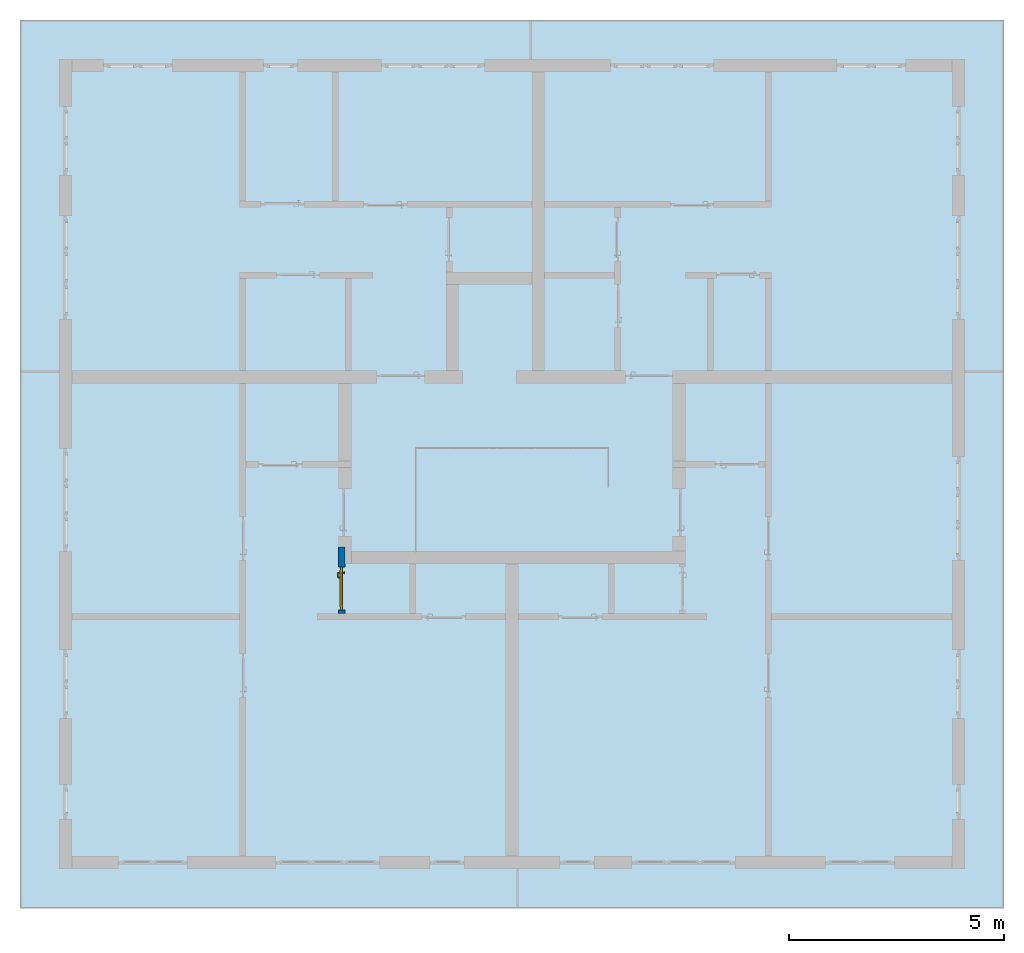
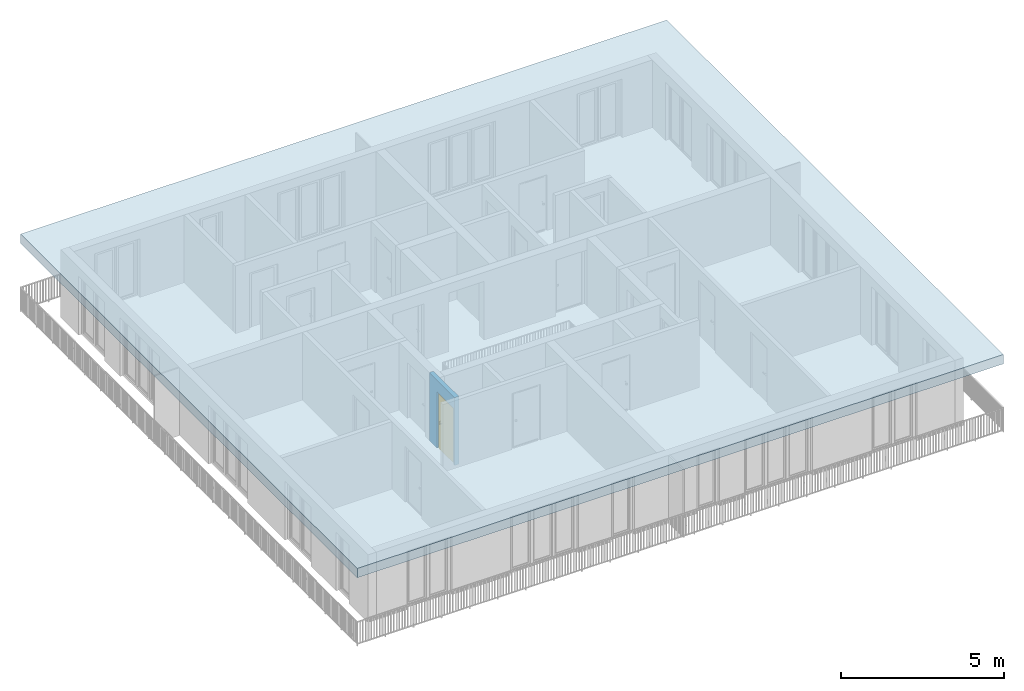
# One storey, part 1 of 54: 1 door, 1 slab, 1 wall, 1 opening.
"""IFC4 building model written with IfcOpenShell, lengths in metres."""

from ifc_helpers import new_model, entity, si_unit, converted_unit, derived_unit, direction, frame, origin_with_axes, place, context, subcontext, project, spatial, polygons, source, transform, mapped, material, type_object, element, fill, save


model = new_model("IFC4")

# Units and contexts
model_context = context("Model", 3, precision=1e-05, world=origin_with_axes(), true_north=direction((0.0, 1.0)))
body_context = subcontext(model_context, "Body", "Model", "MODEL_VIEW")
ifc_project = project(units=[si_unit("LENGTHUNIT", "METRE"), si_unit("AREAUNIT", "SQUARE_METRE"), si_unit("VOLUMEUNIT", "CUBIC_METRE"), converted_unit("PLANEANGLEUNIT", "DEGREE", entity("IfcPlaneAngleMeasure", 0.0174532925199), si_unit("PLANEANGLEUNIT", "RADIAN"), dimensions=[0, 0, 0, 0, 0, 0, 0]), converted_unit("TIMEUNIT", "Year", entity("IfcTimeMeasure", 31556926.0), si_unit("TIMEUNIT", "SECOND"), dimensions=[0, 0, 1, 0, 0, 0, 0]), si_unit("MASSUNIT", "GRAM", prefix="KILO"), si_unit("THERMODYNAMICTEMPERATUREUNIT", "DEGREE_CELSIUS"), si_unit("LUMINOUSINTENSITYUNIT", "LUMEN"), si_unit("ENERGYUNIT", "JOULE", prefix="MEGA"), derived_unit("THERMALCONDUCTANCEUNIT", [(si_unit("POWERUNIT", "WATT"), 1), (si_unit("LENGTHUNIT", "METRE"), -1), (si_unit("THERMODYNAMICTEMPERATUREUNIT", "KELVIN"), -1)]), derived_unit("SPECIFICHEATCAPACITYUNIT", [(si_unit("ENERGYUNIT", "JOULE"), 1), (si_unit("MASSUNIT", "GRAM", prefix="KILO"), -1), (si_unit("THERMODYNAMICTEMPERATUREUNIT", "KELVIN"), -1)]), derived_unit("MASSDENSITYUNIT", [(si_unit("MASSUNIT", "GRAM", prefix="KILO"), 1), (si_unit("VOLUMEUNIT", "CUBIC_METRE"), -1)])], contexts=[model_context])

# Site, building, storey, space
site_placement = place(None, origin_with_axes())
site = spatial("IfcSite", under=ifc_project, at=site_placement, CompositionType="ELEMENT")
building_placement = place(site_placement, origin_with_axes())
building = spatial("IfcBuilding", under=site, at=building_placement, CompositionType="ELEMENT")
storey_placement = place(building_placement, frame((0.0, 0.0, 9.18), z_axis=(0.0, 0.0, 1.0), x_axis=(1.0, 0.0, 0.0)))
storey = spatial("IfcBuildingStorey", under=building, at=storey_placement, Name="3. Geschoss", CompositionType="ELEMENT", Elevation=9.18)
space_placement = place(storey_placement, frame((-3.4421993804, -2.52881223104, 0.0), z_axis=(0.0, 0.0, 1.0), x_axis=(1.0, 0.0, 0.0)))
space = spatial("IfcSpace", under=storey, at=space_placement, CompositionType="ELEMENT", PredefinedType="INTERNAL")

# Slab
ifc_material = material()
slab_type = type_object("IfcSlabType", Name="350", PredefinedType="NOTDEFINED")
slab_placement = place(space_placement, frame((-9.2, 12.35, 2.89), z_axis=(0.0, 0.0, 1.0), x_axis=(1.0, 0.0, 0.0)))
element("IfcSlab", 1, at=slab_placement, inside=space, type_object=slab_type, material=ifc_material, Name="Decke-001", PredefinedType="NOTDEFINED", context=body_context, shape_type="Tessellation", body=[
    polygons([(0.0, 0.0, 0.0), (0.0, 0.0, -0.35), (0.0, -20.65, -0.35), (0.0, -20.65, 0.0), (22.88, 0.0, 0.0), (22.88, 0.0, -0.35), (22.88, -20.65, -0.35), (22.88, -20.65, 0.0)], [[[1, 2, 3, 4]], [[5, 6, 2, 1]], [[3, 2, 6, 7]], [[4, 3, 7, 8]], [[5, 1, 4, 8]], [[8, 7, 6, 5]]], closed=True),
])

# Wall, opening, door
wall_type = type_object("IfcWallType", Name="150", PredefinedType="NOTDEFINED")
wall_placement = place(storey_placement, frame((-5.2421993804, -4.12881223104, 0.0), z_axis=(0.0, 0.0, 1.0), x_axis=(0.0, 1.0, 0.0)))
wall = element("IfcWall", 2, at=wall_placement, inside=storey, type_object=wall_type, material=ifc_material, Name="Wand-002", PredefinedType="NOTDEFINED", context=body_context, shape_type="Tessellation", body=[
    polygons([(0.225, -0.15, 2.1), (0.225, 0.0, 2.1), (1.225, 0.0, 2.1), (1.225, -0.15, 2.1), (0.225, -0.1, 0.0), (0.225, 0.0, 0.0), (0.225, -0.15, 0.0), (0.15, 0.0, 0.0), (0.15, 0.0, 2.54), (1.7, 0.0, 2.54), (1.7, 0.0, 0.0), (1.225, 0.0, 0.0), (1.225, -0.1, 0.0), (1.225, -0.15, 0.0), (1.7, -0.15, 2.54), (0.15, -0.15, 2.54), (0.15, -0.15, 0.0), (1.7, -0.15, 0.0)], [[[1, 2, 3, 4]], [[5, 6, 2, 1, 7]], [[2, 6, 8, 9, 10, 11, 12, 3]], [[4, 3, 12, 13, 14]], [[15, 16, 17, 7, 1, 4, 14, 18]], [[6, 5, 7, 17, 8]], [[9, 8, 17, 16]], [[15, 10, 9, 16]], [[15, 18, 11, 10]], [[13, 12, 11, 18, 14]]], closed=True),
])
opening_placement = place(wall_placement, frame((0.725, 0.0, 0.0), z_axis=(0.0, 0.0, 1.0), x_axis=(1.0, 0.0, 0.0)))
opening = element("IfcOpeningElement", 3, at=opening_placement, cuts=wall, context=body_context, identifier="Reference", shape_type="Tessellation", body=[
    polygons([(0.5, -0.1, 0.0), (0.5, -0.1, 2.1), (0.5, -0.151, 2.1), (0.5, -0.151, 0.0), (0.5, 0.001, 0.0), (0.5, 0.001, 2.1), (-0.5, -0.1, 2.1), (-0.5, -0.151, 2.1), (-0.5, 0.001, 2.1), (-0.5, -0.151, 0.0), (-0.5, -0.1, 0.0), (-0.5, 0.001, 0.0)], [[[1, 2, 3, 4]], [[2, 1, 5, 6]], [[7, 8, 3, 2, 6, 9]], [[8, 10, 4, 3]], [[1, 4, 10, 11, 12, 5]], [[6, 5, 12, 9]], [[7, 11, 10, 8]], [[11, 7, 9, 12]]], closed=True),
])
door_type = type_object("IfcDoorType", Name="Eingang 01 1-Fl 26", OperationType="SINGLE_SWING_LEFT", PredefinedType="DOOR")
shared_shape = source(origin_with_axes(), body_context, "Body", "Tessellation", [
    polygons([(-0.5, -0.05, 0.0), (-0.5, -0.05, 2.1), (-0.5, -0.03, 2.1), (-0.5, -0.03, 0.0), (-0.4, -0.05, 0.0), (-0.4, -0.05, 2.0), (-0.1301, -0.05, 2.0), (-0.0001, -0.05, 2.0), (0.4, -0.05, 2.0), (0.4, -0.05, 0.0), (0.5, -0.05, 0.0), (0.5, -0.05, 2.1), (0.5, -0.03, 2.1), (0.5, -0.03, 0.0), (0.4, -0.03, 0.0), (0.4, -0.03, 2.0), (-0.0001, -0.03, 2.0), (-0.1301, -0.03, 2.0), (-0.4, -0.03, 2.0), (-0.4, -0.03, 0.0)], [[[1, 2, 3, 4]], [[1, 5, 6, 7, 8, 9, 10, 11, 12, 2]], [[2, 12, 13, 3]], [[4, 3, 13, 14, 15, 16, 17, 18, 19, 20]], [[5, 1, 4, 20]], [[6, 5, 20, 19]], [[7, 6, 19, 18]], [[8, 7, 18, 17]], [[9, 8, 17, 16]], [[10, 9, 16, 15]], [[11, 10, 15, 14]], [[12, 11, 14, 13]]], closed=True),
    polygons([(-0.5, -0.03, 0.0), (-0.5, -0.03, 2.1), (-0.5, 0.0, 2.1), (-0.5, 0.0, 0.0), (-0.43, -0.03, 0.0), (-0.43, -0.03, 2.03), (-0.1001, -0.03, 2.03), (-0.0301, -0.03, 2.03), (0.43, -0.03, 2.03), (0.43, -0.03, 0.0), (0.5, -0.03, 0.0), (0.5, -0.03, 2.1), (0.5, 0.0, 2.1), (0.5, 0.0, 0.0), (0.43, 0.0, 0.0), (0.43, 0.0, 2.03), (-0.0301, 0.0, 2.03), (-0.1001, 0.0, 2.03), (-0.43, 0.0, 2.03), (-0.43, 0.0, 0.0)], [[[1, 2, 3, 4]], [[1, 5, 6, 7, 8, 9, 10, 11, 12, 2]], [[2, 12, 13, 3]], [[4, 3, 13, 14, 15, 16, 17, 18, 19, 20]], [[5, 1, 4, 20]], [[6, 5, 20, 19]], [[7, 6, 19, 18]], [[8, 7, 18, 17]], [[9, 8, 17, 16]], [[10, 9, 16, 15]], [[11, 10, 15, 14]], [[12, 11, 14, 13]]], closed=True),
    polygons([(-0.43, 0.01, 0.0), (-0.43, 0.01, 2.03), (0.43, 0.01, 2.03), (0.43, 0.01, 0.0), (-0.43, -0.03, 0.0), (-0.43, -0.03, 2.03), (0.43, -0.03, 2.03), (0.43, -0.03, 0.0)], [[[1, 2, 3, 4]], [[1, 5, 6, 2]], [[2, 6, 7, 3]], [[3, 7, 8, 4]], [[4, 8, 5, 1]], [[8, 7, 6, 5]]], closed=True),
    polygons([(-0.395, -0.05, 0.0), (0.395, -0.05, 0.0), (0.395, -0.05, 0.05), (-0.395, -0.05, 0.05), (-0.395, -0.03, 0.0), (0.395, -0.03, 0.0), (0.395, -0.03, 0.07), (0.395, -0.035, 0.07), (-0.395, -0.035, 0.07), (-0.395, -0.03, 0.07)], [[[1, 2, 3, 4]], [[5, 6, 2, 1]], [[2, 6, 7, 8, 3]], [[4, 3, 8, 9]], [[1, 4, 9, 10, 5]], [[10, 7, 6, 5]], [[9, 8, 7, 10]]], closed=True),
    polygons([(0.3835, 0.02, 1.0733826859), (0.37, 0.02, 1.077), (0.37, 0.0199, 1.077), (0.3835, 0.0199, 1.0733826859), (0.393382685902, 0.02, 1.0635), (0.397, 0.02, 1.05), (0.393382685902, 0.02, 1.0365), (0.3835, 0.02, 1.0266173141), (0.37, 0.02, 1.023), (0.3565, 0.02, 1.0266173141), (0.346617314098, 0.02, 1.0365), (0.343, 0.02, 1.05), (0.346617314098, 0.02, 1.0635), (0.3565, 0.02, 1.0733826859), (0.3565, 0.0199, 1.0733826859), (0.37, 0.0101, 1.077), (0.3835, 0.0101, 1.0733826859), (0.393382685902, 0.0199, 1.0635), (0.397, 0.0199, 1.05), (0.393382685902, 0.0199, 1.0365), (0.3835, 0.0199, 1.0266173141), (0.37, 0.0199, 1.023), (0.3565, 0.0199, 1.0266173141), (0.346617314098, 0.0199, 1.0365), (0.343, 0.0199, 1.05), (0.346617314098, 0.0199, 1.0635), (0.3565, 0.0101, 1.0733826859), (0.37, 0.01, 1.077), (0.3835, 0.01, 1.0733826859), (0.393382685902, 0.0101, 1.0635), (0.397, 0.0101, 1.05), (0.393382685902, 0.0101, 1.0365), (0.3835, 0.0101, 1.0266173141), (0.37, 0.0101, 1.023), (0.3565, 0.0101, 1.0266173141), (0.346617314098, 0.0101, 1.0365), (0.343, 0.0101, 1.05), (0.346617314098, 0.0101, 1.0635), (0.3565, 0.01, 1.0733826859), (0.346617314098, 0.01, 1.0635), (0.343, 0.01, 1.05), (0.346617314098, 0.01, 1.0365), (0.3565, 0.01, 1.0266173141), (0.37, 0.01, 1.023), (0.3835, 0.01, 1.0266173141), (0.393382685902, 0.01, 1.0365), (0.397, 0.01, 1.05), (0.393382685902, 0.01, 1.0635)], [[[1, 2, 3, 4]], [[2, 1, 5, 6, 7, 8, 9, 10, 11, 12, 13, 14]], [[2, 14, 15, 3]], [[4, 3, 16, 17]], [[5, 1, 4, 18]], [[6, 5, 18, 19]], [[7, 6, 19, 20]], [[8, 7, 20, 21]], [[9, 8, 21, 22]], [[10, 9, 22, 23]], [[11, 10, 23, 24]], [[12, 11, 24, 25]], [[13, 12, 25, 26]], [[14, 13, 26, 15]], [[3, 15, 27, 16]], [[17, 16, 28, 29]], [[18, 4, 17, 30]], [[19, 18, 30, 31]], [[20, 19, 31, 32]], [[21, 20, 32, 33]], [[22, 21, 33, 34]], [[23, 22, 34, 35]], [[24, 23, 35, 36]], [[25, 24, 36, 37]], [[26, 25, 37, 38]], [[15, 26, 38, 27]], [[16, 27, 39, 28]], [[28, 39, 40, 41, 42, 43, 44, 45, 46, 47, 48, 29]], [[30, 17, 29, 48]], [[31, 30, 48, 47]], [[32, 31, 47, 46]], [[33, 32, 46, 45]], [[34, 33, 45, 44]], [[35, 34, 44, 43]], [[36, 35, 43, 42]], [[37, 36, 42, 41]], [[38, 37, 41, 40]], [[27, 38, 40, 39]]], closed=True),
    polygons([(0.362532169224, 0.019, 0.959692280177), (0.363279754556, 0.019, 0.961639806549), (0.35705, 0.019, 0.972430057958), (0.347569942042, 0.019, 0.96295), (0.365, 0.019, 0.952886751346), (0.365, 0.019, 0.9544), (0.362532169224, 0.02, 0.959692280177), (0.363279754556, 0.02, 0.961639806549), (0.364624817685, 0.02, 0.965143815798), (0.364624817685, 0.019, 0.965143815798), (0.37, 0.019, 0.967425445323), (0.37, 0.019, 0.9759), (0.357, 0.019, 0.972516660498), (0.347483339502, 0.019, 0.963), (0.365, 0.019, 0.95), (0.3441, 0.019, 0.95), (0.365, 0.019, 0.947113248654), (0.365, 0.019, 0.941339745962), (0.365, 0.019, 0.9375), (0.365, 0.02, 0.9375), (0.365, 0.02, 0.941339745962), (0.365, 0.02, 0.947113248654), (0.365, 0.02, 0.95), (0.365, 0.02, 0.952886751346), (0.365, 0.02, 0.9544), (0.346703916638, 0.02, 0.96345), (0.35655, 0.02, 0.973296083362), (0.37, 0.02, 0.9769), (0.37, 0.02, 0.967425445323), (0.375375182315, 0.019, 0.965143815798), (0.376720245444, 0.019, 0.961639806549), (0.38295, 0.019, 0.972430057958), (0.37, 0.019, 0.976), (0.357, 0.0189, 0.972516660498), (0.347483339502, 0.0189, 0.963), (0.344, 0.019, 0.95), (0.347569942042, 0.019, 0.93705), (0.35705, 0.019, 0.927569942042), (0.37, 0.019, 0.9241), (0.37, 0.019, 0.9325), (0.366464466094, 0.019, 0.933964466094), (0.366464466094, 0.02, 0.933964466094), (0.37, 0.02, 0.9231), (0.35655, 0.02, 0.926703916638), (0.37, 0.02, 0.9325), (0.346703916638, 0.02, 0.93655), (0.3431, 0.02, 0.95), (0.346617314098, 0.02, 0.9635), (0.3565, 0.02, 0.973382685902), (0.37, 0.02, 0.977), (0.375375182315, 0.02, 0.965143815798), (0.38345, 0.02, 0.973296083362), (0.376720245444, 0.02, 0.961639806549), (0.377467830776, 0.02, 0.959692280177), (0.377467830776, 0.019, 0.959692280177), (0.375, 0.019, 0.9544), (0.375, 0.019, 0.952886751346), (0.392430057958, 0.019, 0.96295), (0.383, 0.019, 0.972516660498), (0.37, 0.0189, 0.976), (0.357, 0.0101, 0.972516660498), (0.347483339502, 0.0101, 0.963), (0.344, 0.0189, 0.95), (0.347483339502, 0.019, 0.937), (0.357, 0.019, 0.927483339502), (0.37, 0.019, 0.924), (0.38295, 0.019, 0.927569942042), (0.375, 0.019, 0.941339745962), (0.375, 0.019, 0.9375), (0.373535533906, 0.019, 0.933964466094), (0.37, 0.02, 0.923), (0.3565, 0.02, 0.926617314098), (0.38345, 0.02, 0.926703916638), (0.373535533906, 0.02, 0.933964466094), (0.375, 0.02, 0.9375), (0.375, 0.02, 0.941339745962), (0.346617314098, 0.02, 0.9365), (0.343, 0.02, 0.95), (0.346617314098, 0.0199, 0.9635), (0.3565, 0.0199, 0.973382685902), (0.37, 0.0199, 0.977), (0.3835, 0.02, 0.973382685902), (0.393296083362, 0.02, 0.96345), (0.375, 0.02, 0.952886751346), (0.375, 0.02, 0.9544), (0.375, 0.02, 0.95), (0.375, 0.02, 0.947113248654), (0.375, 0.019, 0.947113248654), (0.375, 0.019, 0.95), (0.3959, 0.019, 0.95), (0.392516660498, 0.019, 0.963), (0.383, 0.0189, 0.972516660498), (0.37, 0.0101, 0.976), (0.357, 0.01, 0.972516660498), (0.347483339502, 0.01, 0.963), (0.344, 0.0101, 0.95), (0.347483339502, 0.0189, 0.937), (0.357, 0.0189, 0.927483339502), (0.37, 0.0189, 0.924), (0.383, 0.019, 0.927483339502), (0.392430057958, 0.019, 0.93705), (0.37, 0.0199, 0.923), (0.3565, 0.0199, 0.926617314098), (0.3835, 0.02, 0.926617314098), (0.393296083362, 0.02, 0.93655), (0.346617314098, 0.0199, 0.9365), (0.343, 0.0199, 0.95), (0.346617314098, 0.0101, 0.9635), (0.3565, 0.0101, 0.973382685902), (0.37, 0.0101, 0.977), (0.3835, 0.0199, 0.973382685902), (0.393382685902, 0.02, 0.9635), (0.3969, 0.02, 0.95), (0.396, 0.019, 0.95), (0.392516660498, 0.0189, 0.963), (0.383, 0.0101, 0.972516660498), (0.37, 0.01, 0.976), (0.35695, 0.01, 0.972603263039), (0.347396736961, 0.01, 0.96305), (0.344, 0.01, 0.95), (0.347483339502, 0.0101, 0.937), (0.357, 0.0101, 0.927483339502), (0.37, 0.0101, 0.924), (0.383, 0.0189, 0.927483339502), (0.392516660498, 0.019, 0.937), (0.37, 0.0101, 0.923), (0.3565, 0.0101, 0.926617314098), (0.3835, 0.0199, 0.926617314098), (0.393382685902, 0.02, 0.9365), (0.346617314098, 0.0101, 0.9365), (0.343, 0.0101, 0.95), (0.346617314098, 0.01, 0.9635), (0.3565, 0.01, 0.973382685902), (0.37, 0.01, 0.977), (0.3835, 0.0101, 0.973382685902), (0.393382685902, 0.0199, 0.9635), (0.397, 0.02, 0.95), (0.396, 0.0189, 0.95), (0.392516660498, 0.0101, 0.963), (0.383, 0.01, 0.972516660498), (0.37, 0.01, 0.9761), (0.35655, 0.01, 0.973296083362), (0.346703916638, 0.01, 0.96345), (0.3439, 0.01, 0.95), (0.347483339502, 0.01, 0.937), (0.357, 0.01, 0.927483339502), (0.37, 0.01, 0.924), (0.383, 0.0101, 0.927483339502), (0.392516660498, 0.0189, 0.937), (0.37, 0.01, 0.923), (0.3565, 0.01, 0.926617314098), (0.3835, 0.0101, 0.926617314098), (0.393382685902, 0.0199, 0.9365), (0.346617314098, 0.01, 0.9365), (0.343, 0.01, 0.95), (0.37, 0.01, 0.9769), (0.3835, 0.01, 0.973382685902), (0.393382685902, 0.0101, 0.9635), (0.397, 0.0199, 0.95), (0.396, 0.0101, 0.95), (0.392516660498, 0.01, 0.963), (0.38305, 0.01, 0.972603263039), (0.3431, 0.01, 0.95), (0.347396736961, 0.01, 0.93695), (0.35695, 0.01, 0.927396736961), (0.37, 0.01, 0.9239), (0.383, 0.01, 0.927483339502), (0.392516660498, 0.0101, 0.937), (0.37, 0.01, 0.9231), (0.35655, 0.01, 0.926703916638), (0.3835, 0.01, 0.926617314098), (0.393382685902, 0.0101, 0.9365), (0.346703916638, 0.01, 0.93655), (0.38345, 0.01, 0.973296083362), (0.393382685902, 0.01, 0.9635), (0.397, 0.0101, 0.95), (0.396, 0.01, 0.95), (0.392603263039, 0.01, 0.96305), (0.38305, 0.01, 0.927396736961), (0.392516660498, 0.01, 0.937), (0.38345, 0.01, 0.926703916638), (0.393382685902, 0.01, 0.9365), (0.393296083362, 0.01, 0.96345), (0.397, 0.01, 0.95), (0.3961, 0.01, 0.95), (0.392603263039, 0.01, 0.93695), (0.393296083362, 0.01, 0.93655), (0.3969, 0.01, 0.95)], [[[1, 2, 3, 4, 5, 6]], [[1, 7, 8, 9, 10, 2]], [[10, 11, 12, 3, 2]], [[4, 3, 13, 14]], [[15, 5, 4, 16]], [[6, 5, 15, 17, 18, 19, 20, 21, 22, 23, 24, 25]], [[6, 25, 7, 1]], [[7, 25, 24, 26, 27, 8]], [[9, 8, 27, 28, 29]], [[10, 9, 29, 11]], [[30, 31, 32, 12, 11]], [[3, 12, 33, 13]], [[14, 13, 34, 35]], [[16, 4, 14, 36]], [[17, 15, 16, 37]], [[18, 17, 37, 38]], [[38, 39, 40, 41, 19, 18]], [[19, 41, 42, 20]], [[43, 44, 21, 20, 42, 45]], [[22, 21, 44, 46]], [[23, 22, 46, 47]], [[24, 23, 47, 26]], [[48, 49, 27, 26]], [[49, 50, 28, 27]], [[51, 29, 28, 52, 53]], [[11, 29, 51, 30]], [[30, 51, 53, 54, 55, 31]], [[55, 56, 57, 58, 32, 31]], [[12, 32, 59, 33]], [[13, 33, 60, 34]], [[35, 34, 61, 62]], [[36, 14, 35, 63]], [[37, 16, 36, 64]], [[38, 37, 64, 65]], [[39, 38, 65, 66]], [[39, 67, 68, 69, 70, 40]], [[41, 40, 45, 42]], [[71, 72, 44, 43]], [[73, 43, 45, 74, 75, 76]], [[72, 77, 46, 44]], [[77, 78, 47, 46]], [[78, 48, 26, 47]], [[79, 80, 49, 48]], [[80, 81, 50, 49]], [[50, 82, 52, 28]], [[54, 53, 52, 83, 84, 85]], [[55, 54, 85, 56]], [[85, 84, 86, 87, 76, 75, 69, 68, 88, 89, 57, 56]], [[57, 89, 90, 58]], [[32, 58, 91, 59]], [[33, 59, 92, 60]], [[34, 60, 93, 61]], [[62, 61, 94, 95]], [[63, 35, 62, 96]], [[64, 36, 63, 97]], [[65, 64, 97, 98]], [[66, 65, 98, 99]], [[67, 39, 66, 100]], [[88, 68, 67, 101]], [[70, 69, 75, 74]], [[40, 70, 74, 45]], [[102, 103, 72, 71]], [[104, 71, 43, 73]], [[76, 87, 105, 73]], [[103, 106, 77, 72]], [[106, 107, 78, 77]], [[107, 79, 48, 78]], [[108, 109, 80, 79]], [[109, 110, 81, 80]], [[81, 111, 82, 50]], [[82, 112, 83, 52]], [[86, 84, 83, 113]], [[87, 86, 113, 105]], [[89, 88, 101, 90]], [[58, 90, 114, 91]], [[59, 91, 115, 92]], [[60, 92, 116, 93]], [[61, 93, 117, 94]], [[95, 94, 118, 119]], [[96, 62, 95, 120]], [[97, 63, 96, 121]], [[98, 97, 121, 122]], [[99, 98, 122, 123]], [[100, 66, 99, 124]], [[101, 67, 100, 125]], [[126, 127, 103, 102]], [[128, 102, 71, 104]], [[129, 104, 73, 105]], [[127, 130, 106, 103]], [[130, 131, 107, 106]], [[131, 108, 79, 107]], [[132, 133, 109, 108]], [[133, 134, 110, 109]], [[110, 135, 111, 81]], [[111, 136, 112, 82]], [[112, 137, 113, 83]], [[137, 129, 105, 113]], [[90, 101, 125, 114]], [[91, 114, 138, 115]], [[92, 115, 139, 116]], [[93, 116, 140, 117]], [[94, 117, 141, 118]], [[119, 118, 142, 143]], [[120, 95, 119, 144]], [[121, 96, 120, 145]], [[122, 121, 145, 146]], [[123, 122, 146, 147]], [[124, 99, 123, 148]], [[125, 100, 124, 149]], [[150, 151, 127, 126]], [[152, 126, 102, 128]], [[153, 128, 104, 129]], [[151, 154, 130, 127]], [[154, 155, 131, 130]], [[155, 132, 108, 131]], [[143, 142, 133, 132]], [[142, 156, 134, 133]], [[134, 157, 135, 110]], [[135, 158, 136, 111]], [[136, 159, 137, 112]], [[159, 153, 129, 137]], [[114, 125, 149, 138]], [[115, 138, 160, 139]], [[116, 139, 161, 140]], [[117, 140, 162, 141]], [[118, 141, 156, 142]], [[144, 119, 143, 163]], [[145, 120, 144, 164]], [[146, 145, 164, 165]], [[147, 146, 165, 166]], [[148, 123, 147, 167]], [[149, 124, 148, 168]], [[169, 170, 151, 150]], [[171, 150, 126, 152]], [[172, 152, 128, 153]], [[170, 173, 154, 151]], [[173, 163, 155, 154]], [[163, 143, 132, 155]], [[156, 174, 157, 134]], [[157, 175, 158, 135]], [[158, 176, 159, 136]], [[176, 172, 153, 159]], [[138, 149, 168, 160]], [[139, 160, 177, 161]], [[140, 161, 178, 162]], [[141, 162, 174, 156]], [[164, 144, 163, 173]], [[165, 164, 173, 170]], [[166, 165, 170, 169]], [[167, 147, 166, 179]], [[168, 148, 167, 180]], [[181, 169, 150, 171]], [[182, 171, 152, 172]], [[174, 183, 175, 157]], [[175, 184, 176, 158]], [[184, 182, 172, 176]], [[160, 168, 180, 177]], [[161, 177, 185, 178]], [[162, 178, 183, 174]], [[179, 166, 169, 181]], [[180, 167, 179, 186]], [[187, 181, 171, 182]], [[183, 188, 184, 175]], [[188, 187, 182, 184]], [[177, 180, 186, 185]], [[178, 185, 188, 183]], [[186, 179, 181, 187]], [[185, 186, 187, 188]]], closed=True),
    polygons([(0.38, 0.02, 1.05), (0.377071067812, 0.02, 1.04292893219), (0.377071067812, 0.050696439392, 1.04292893219), (0.38, 0.0509849140336, 1.05), (0.37, 0.02, 1.04), (0.37, 0.05, 1.04), (0.375518993221, 0.0584992452783, 1.04292893219), (0.378277987014, 0.0596420579258, 1.05), (0.377071067812, 0.02, 1.05707106781), (0.377071067812, 0.050696439392, 1.05707106781), (0.362928932188, 0.02, 1.04292893219), (0.362928932188, 0.049303560608, 1.04292893219), (0.368858192988, 0.0557402514855, 1.04), (0.370704557509, 0.0657045575088, 1.04292893219), (0.372816199938, 0.0678161999379, 1.05), (0.375518993221, 0.0584992452783, 1.05707106781), (0.37, 0.02, 1.06), (0.37, 0.05, 1.06), (0.36, 0.02, 1.05), (0.36, 0.0490150859664, 1.05), (0.362197392755, 0.0529812576926, 1.04292893219), (0.365606601718, 0.0606066017178, 1.04), (0.363499245278, 0.0705189932208, 1.04292893219), (0.364642057926, 0.0732779870137, 1.05), (0.370704557509, 0.0657045575088, 1.05707106781), (0.368858192988, 0.0557402514855, 1.06), (0.362928932188, 0.02, 1.05707106781), (0.362928932188, 0.049303560608, 1.05707106781), (0.359438398962, 0.0518384450452, 1.05), (0.360508645927, 0.0555086459268, 1.04292893219), (0.360740251485, 0.0638581929877, 1.04), (0.355696439392, 0.0720710678119, 1.04292893219), (0.355984914034, 0.075, 1.05), (0.363499245278, 0.0705189932208, 1.05707106781), (0.365606601718, 0.0606066017178, 1.06), (0.362197392755, 0.0529812576926, 1.05707106781), (0.358397003498, 0.0533970034977, 1.05), (0.357981257693, 0.0571973927545, 1.04292893219), (0.355, 0.065, 1.04), (0.274303560608, 0.0720710678119, 1.04292893219), (0.274015085966, 0.075, 1.05), (0.355696439392, 0.0720710678119, 1.05707106781), (0.360740251485, 0.0638581929877, 1.06), (0.360508645927, 0.0555086459268, 1.05707106781), (0.356838445045, 0.0544383989617, 1.05), (0.354303560608, 0.0579289321881, 1.04292893219), (0.275, 0.065, 1.04), (0.266500754722, 0.0705189932208, 1.04292893219), (0.265357942074, 0.0732779870137, 1.05), (0.274303560608, 0.0720710678119, 1.05707106781), (0.355, 0.065, 1.06), (0.357981257693, 0.0571973927545, 1.05707106781), (0.354015085966, 0.055, 1.05), (0.275696439392, 0.0579289321881, 1.04292893219), (0.269259748515, 0.0638581929877, 1.04), (0.259295442491, 0.0657045575088, 1.04292893219), (0.257183800062, 0.0678161999379, 1.05), (0.266500754722, 0.0705189932208, 1.05707106781), (0.275, 0.065, 1.06), (0.354303560608, 0.0579289321881, 1.05707106781), (0.275984914034, 0.055, 1.05), (0.272018742307, 0.0571973927545, 1.04292893219), (0.264393398282, 0.0606066017178, 1.04), (0.254481006779, 0.0584992452783, 1.04292893219), (0.251722012986, 0.0596420579258, 1.05), (0.259295442491, 0.0657045575088, 1.05707106781), (0.269259748515, 0.0638581929877, 1.06), (0.275696439392, 0.0579289321881, 1.05707106781), (0.273161554955, 0.0544383989617, 1.05), (0.269491354073, 0.0555086459268, 1.04292893219), (0.261141807012, 0.0557402514855, 1.04), (0.252928932188, 0.050696439392, 1.04292893219), (0.25, 0.0509849140336, 1.05), (0.254481006779, 0.0584992452783, 1.05707106781), (0.264393398282, 0.0606066017178, 1.06), (0.272018742307, 0.0571973927545, 1.05707106781), (0.271602996502, 0.0533970034977, 1.05), (0.267802607245, 0.0529812576926, 1.04292893219), (0.26, 0.05, 1.04), (0.252928932188, 0.02, 1.04292893219), (0.25, 0.02, 1.05), (0.252928932188, 0.050696439392, 1.05707106781), (0.261141807012, 0.0557402514855, 1.06), (0.269491354073, 0.0555086459268, 1.05707106781), (0.270561601038, 0.0518384450452, 1.05), (0.267071067812, 0.049303560608, 1.04292893219), (0.26, 0.02, 1.04), (0.267071067812, 0.02, 1.04292893219), (0.27, 0.02, 1.05), (0.267071067812, 0.02, 1.05707106781), (0.26, 0.02, 1.06), (0.252928932188, 0.02, 1.05707106781), (0.26, 0.05, 1.06), (0.267802607245, 0.0529812576926, 1.05707106781), (0.27, 0.0490150859664, 1.05), (0.267071067812, 0.049303560608, 1.05707106781)], [[[1, 2, 3, 4]], [[2, 5, 6, 3]], [[4, 3, 7, 8]], [[9, 1, 4, 10]], [[5, 11, 12, 6]], [[3, 6, 13, 7]], [[8, 7, 14, 15]], [[10, 4, 8, 16]], [[17, 9, 10, 18]], [[11, 19, 20, 12]], [[6, 12, 21, 13]], [[7, 13, 22, 14]], [[15, 14, 23, 24]], [[16, 8, 15, 25]], [[18, 10, 16, 26]], [[27, 17, 18, 28]], [[19, 27, 28, 20]], [[12, 20, 29, 21]], [[13, 21, 30, 22]], [[14, 22, 31, 23]], [[24, 23, 32, 33]], [[25, 15, 24, 34]], [[26, 16, 25, 35]], [[28, 18, 26, 36]], [[20, 28, 36, 29]], [[21, 29, 37, 30]], [[22, 30, 38, 31]], [[23, 31, 39, 32]], [[33, 32, 40, 41]], [[34, 24, 33, 42]], [[35, 25, 34, 43]], [[36, 26, 35, 44]], [[29, 36, 44, 37]], [[30, 37, 45, 38]], [[31, 38, 46, 39]], [[32, 39, 47, 40]], [[41, 40, 48, 49]], [[42, 33, 41, 50]], [[43, 34, 42, 51]], [[44, 35, 43, 52]], [[37, 44, 52, 45]], [[38, 45, 53, 46]], [[39, 46, 54, 47]], [[40, 47, 55, 48]], [[49, 48, 56, 57]], [[50, 41, 49, 58]], [[51, 42, 50, 59]], [[52, 43, 51, 60]], [[45, 52, 60, 53]], [[46, 53, 61, 54]], [[47, 54, 62, 55]], [[48, 55, 63, 56]], [[57, 56, 64, 65]], [[58, 49, 57, 66]], [[59, 50, 58, 67]], [[60, 51, 59, 68]], [[53, 60, 68, 61]], [[54, 61, 69, 62]], [[55, 62, 70, 63]], [[56, 63, 71, 64]], [[65, 64, 72, 73]], [[66, 57, 65, 74]], [[67, 58, 66, 75]], [[68, 59, 67, 76]], [[61, 68, 76, 69]], [[62, 69, 77, 70]], [[63, 70, 78, 71]], [[64, 71, 79, 72]], [[73, 72, 80, 81]], [[74, 65, 73, 82]], [[75, 66, 74, 83]], [[76, 67, 75, 84]], [[69, 76, 84, 77]], [[70, 77, 85, 78]], [[71, 78, 86, 79]], [[72, 79, 87, 80]], [[81, 80, 87, 88, 89, 90, 91, 92]], [[82, 73, 81, 92]], [[83, 74, 82, 93]], [[84, 75, 83, 94]], [[77, 84, 94, 85]], [[78, 85, 95, 86]], [[79, 86, 88, 87]], [[86, 95, 89, 88]], [[95, 96, 90, 89]], [[96, 93, 91, 90]], [[93, 82, 92, 91]], [[94, 83, 93, 96]], [[85, 94, 96, 95]]], closed=False),
    polygons([(0.364696699141, -0.035, 1.04469669914), (0.3625, -0.035, 1.05), (0.364696699141, -0.035, 1.05530330086), (0.37, -0.035, 1.0575), (0.375303300859, -0.035, 1.05530330086), (0.3775, -0.035, 1.05), (0.375303300859, -0.035, 1.04469669914), (0.37, -0.035, 1.0425), (0.364696699141, -0.075, 1.04469669914), (0.3625, -0.075, 1.05), (0.364696699141, -0.075, 1.05530330086), (0.37, -0.075, 1.0575), (0.375303300859, -0.075, 1.05530330086), (0.3775, -0.075, 1.05), (0.375303300859, -0.075, 1.04469669914), (0.37, -0.075, 1.0425)], [[[1, 2, 3, 4, 5, 6, 7, 8]], [[1, 9, 10, 2]], [[2, 10, 11, 3]], [[3, 11, 12, 4]], [[4, 12, 13, 5]], [[5, 13, 14, 6]], [[6, 14, 15, 7]], [[7, 15, 16, 8]], [[8, 16, 9, 1]], [[9, 16, 15, 14, 13, 12, 11, 10]]], closed=True),
    polygons([(0.395, -0.03, 0.975), (0.395, -0.035, 0.975), (0.393096988313, -0.035, 0.965432914191), (0.393096988313, -0.03, 0.965432914191), (0.395, -0.03, 1.1), (0.395, -0.035, 1.1), (0.393096988313, -0.035, 1.10956708581), (0.38767766953, -0.035, 1.11767766953), (0.379567085809, -0.035, 1.12309698831), (0.37, -0.035, 1.125), (0.360432914191, -0.035, 1.12309698831), (0.35232233047, -0.035, 1.11767766953), (0.346903011687, -0.035, 1.10956708581), (0.345, -0.035, 1.1), (0.345, -0.035, 0.975), (0.346903011687, -0.035, 0.965432914191), (0.35232233047, -0.035, 0.95732233047), (0.360432914191, -0.035, 0.951903011687), (0.37, -0.035, 0.95), (0.379567085809, -0.035, 0.951903011687), (0.38767766953, -0.035, 0.95732233047), (0.38767766953, -0.03, 0.95732233047), (0.379567085809, -0.03, 0.951903011687), (0.37, -0.03, 0.95), (0.360432914191, -0.03, 0.951903011687), (0.35232233047, -0.03, 0.95732233047), (0.346903011687, -0.03, 0.965432914191), (0.345, -0.03, 0.975), (0.345, -0.03, 1.1), (0.346903011687, -0.03, 1.10956708581), (0.35232233047, -0.03, 1.11767766953), (0.360432914191, -0.03, 1.12309698831), (0.37, -0.03, 1.125), (0.379567085809, -0.03, 1.12309698831), (0.38767766953, -0.03, 1.11767766953), (0.393096988313, -0.03, 1.10956708581)], [[[1, 2, 3, 4]], [[5, 6, 2, 1]], [[2, 6, 7, 8, 9, 10, 11, 12, 13, 14, 15, 16, 17, 18, 19, 20, 21, 3]], [[4, 3, 21, 22]], [[1, 4, 22, 23, 24, 25, 26, 27, 28, 29, 30, 31, 32, 33, 34, 35, 36, 5]], [[36, 7, 6, 5]], [[35, 8, 7, 36]], [[34, 9, 8, 35]], [[33, 10, 9, 34]], [[32, 11, 10, 33]], [[31, 12, 11, 32]], [[30, 13, 12, 31]], [[29, 14, 13, 30]], [[28, 15, 14, 29]], [[27, 16, 15, 28]], [[26, 17, 16, 27]], [[25, 18, 17, 26]], [[24, 19, 18, 25]], [[23, 20, 19, 24]], [[22, 21, 20, 23]]], closed=True),
    polygons([(0.39, -0.075, 1.08), (0.39, -0.09, 1.08), (0.395, -0.09, 1.07866025404), (0.395, -0.075, 1.07866025404), (0.35, -0.075, 1.08), (0.35, -0.09, 1.08), (0.345, -0.09, 1.07866025404), (0.341339745962, -0.09, 1.075), (0.34, -0.09, 1.07), (0.34, -0.09, 1.03), (0.341339745962, -0.09, 1.025), (0.345, -0.09, 1.02133974596), (0.35, -0.09, 1.02), (0.39, -0.09, 1.02), (0.395, -0.09, 1.02133974596), (0.398660254038, -0.09, 1.025), (0.4, -0.09, 1.03), (0.4, -0.09, 1.07), (0.398660254038, -0.09, 1.075), (0.398660254038, -0.075, 1.075), (0.4, -0.075, 1.07), (0.4, -0.075, 1.03), (0.398660254038, -0.075, 1.025), (0.395, -0.075, 1.02133974596), (0.39, -0.075, 1.02), (0.35, -0.075, 1.02), (0.345, -0.075, 1.02133974596), (0.341339745962, -0.075, 1.025), (0.34, -0.075, 1.03), (0.34, -0.075, 1.07), (0.341339745962, -0.075, 1.075), (0.345, -0.075, 1.07866025404)], [[[1, 2, 3, 4]], [[5, 6, 2, 1]], [[2, 6, 7, 8, 9, 10, 11, 12, 13, 14, 15, 16, 17, 18, 19, 3]], [[4, 3, 19, 20]], [[1, 4, 20, 21, 22, 23, 24, 25, 26, 27, 28, 29, 30, 31, 32, 5]], [[32, 7, 6, 5]], [[31, 8, 7, 32]], [[30, 9, 8, 31]], [[29, 10, 9, 30]], [[28, 11, 10, 29]], [[27, 12, 11, 28]], [[26, 13, 12, 27]], [[25, 14, 13, 26]], [[24, 15, 14, 25]], [[23, 16, 15, 24]], [[22, 17, 16, 23]], [[21, 18, 17, 22]], [[20, 19, 18, 21]]], closed=True),
])
door_placement = place(opening_placement, frame((-0.4, 0.0, 0.0), z_axis=(0.0, 0.0, 1.0), x_axis=(1.0, 0.0, 0.0)))
door = element("IfcDoor", 4, at=door_placement, inside=storey, type_object=door_type, OverallHeight=2.1, OverallWidth=1.0, PredefinedType="DOOR", context=body_context, shape_type="MappedRepresentation", body=[
    mapped(shared_shape, transform((0.4, -0.05, 0.0))),
])
fill(opening, door)

save(model, "model.ifc")
